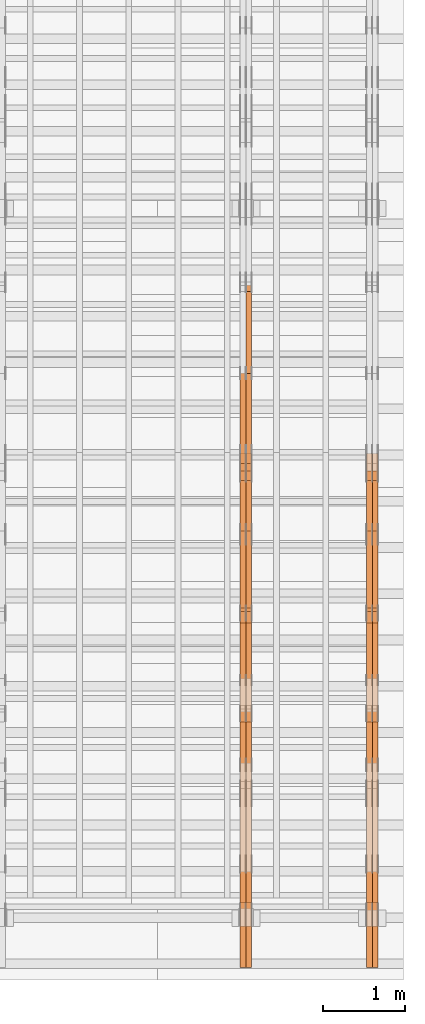
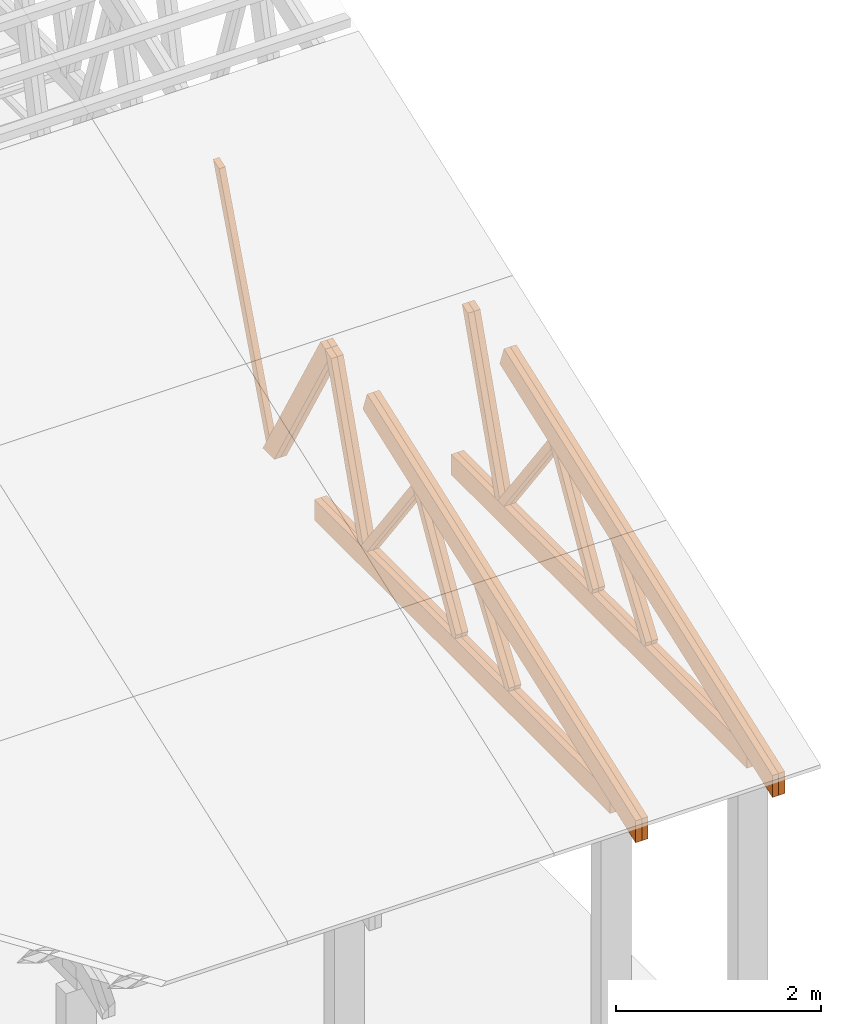
# One storey, part 54 of 189: 27 proxies.
"""IFC2X3 building model written with IfcOpenShell, lengths in millimetres."""

from ifc_helpers import new_model, entity, si_unit, converted_unit, derived_unit, direction, frame, origin, place, context, subcontext, project, spatial, polyline, outline, extrude, source, transform, mapped, material, type_object, type_shapes, element, save


model = new_model("IFC2X3")

# Units and contexts
model_context = context("Model", 3, precision=0.01, world=origin(), true_north=direction((6.12303176911189e-17, 1.0)))
body_context = subcontext(model_context, "Body", "Model", "MODEL_VIEW")
ifc_project = project(units=[si_unit("LENGTHUNIT", "METRE", prefix="MILLI"), si_unit("AREAUNIT", "SQUARE_METRE"), si_unit("VOLUMEUNIT", "CUBIC_METRE"), converted_unit("PLANEANGLEUNIT", "DEGREE", entity("IfcRatioMeasure", 0.0174532925199433), si_unit("PLANEANGLEUNIT", "RADIAN"), dimensions=[0, 0, 0, 0, 0, 0, 0]), si_unit("MASSUNIT", "GRAM", prefix="KILO"), derived_unit("MASSDENSITYUNIT", [(si_unit("MASSUNIT", "GRAM", prefix="KILO"), 1), (si_unit("LENGTHUNIT", "METRE"), -3)]), si_unit("TIMEUNIT", "SECOND"), si_unit("FREQUENCYUNIT", "HERTZ"), si_unit("THERMODYNAMICTEMPERATUREUNIT", "DEGREE_CELSIUS"), derived_unit("THERMALTRANSMITTANCEUNIT", [(si_unit("MASSUNIT", "GRAM", prefix="KILO"), 1), (si_unit("THERMODYNAMICTEMPERATUREUNIT", "KELVIN"), -1), (si_unit("TIMEUNIT", "SECOND"), -3)]), derived_unit("VOLUMETRICFLOWRATEUNIT", [(si_unit("LENGTHUNIT", "METRE"), 3), (si_unit("TIMEUNIT", "SECOND"), -1)]), si_unit("ELECTRICCURRENTUNIT", "AMPERE"), si_unit("ELECTRICVOLTAGEUNIT", "VOLT"), si_unit("POWERUNIT", "WATT"), si_unit("FORCEUNIT", "NEWTON"), si_unit("ILLUMINANCEUNIT", "LUX"), si_unit("LUMINOUSFLUXUNIT", "LUMEN"), si_unit("LUMINOUSINTENSITYUNIT", "CANDELA"), derived_unit("USERDEFINED", [(si_unit("MASSUNIT", "GRAM", prefix="KILO"), -1), (si_unit("LENGTHUNIT", "METRE"), -2), (si_unit("TIMEUNIT", "SECOND"), 3), (si_unit("LUMINOUSFLUXUNIT", "LUMEN"), 1)]), derived_unit("LINEARVELOCITYUNIT", [(si_unit("LENGTHUNIT", "METRE"), 1), (si_unit("TIMEUNIT", "SECOND"), -1)]), si_unit("PRESSUREUNIT", "PASCAL"), derived_unit("USERDEFINED", [(si_unit("LENGTHUNIT", "METRE"), -2), (si_unit("MASSUNIT", "GRAM", prefix="KILO"), 1), (si_unit("TIMEUNIT", "SECOND"), -2)])], contexts=[model_context])

# Site, building, storey
site_placement = place(None, origin())
site = spatial("IfcSite", under=ifc_project, at=site_placement, CompositionType="ELEMENT")
building_placement = place(site_placement, origin())
building = spatial("IfcBuilding", under=site, at=building_placement, CompositionType="ELEMENT")
storey_placement = place(building_placement, origin())
storey = spatial("IfcBuildingStorey", under=building, at=storey_placement, Name="Default", CompositionType="ELEMENT", Elevation=0.0)

# Proxies
ifc_material_1 = material(Name="IfcSurfaceStyle #271792")
building_element_proxy_type_1 = type_object("IfcBuildingElementProxyType", Name="T1-W9 271790", PredefinedType="NOTDEFINED", material=ifc_material_1)
shared_shape_1 = source(origin(), body_context, "Body", "SweptSolid", [
    extrude(outline(polyline([(-1227.3969292634, -47.5000382896404), (793.242467803064, -47.5000382896404), (809.267705296822, 1.0956605530188e-05), (776.329919980315, 47.5000328113376), (-1151.4431638168, 47.5000328113376), (-1227.3969292634, -47.5000382896404)])), frame((809.267705296822, 47.5000328113376, 0.0), z_axis=(0.0, 0.0, 1.0), x_axis=(-1.0, 0.0, 0.0)), (0.0, 0.0, 1.0), 69.9999999999999),
])
type_shapes(building_element_proxy_type_1, [shared_shape_1])
proxy_1_placement = place(building_placement, frame((49840.0, 4809.76380889125, 260.184242613649), z_axis=(-1.0, 0.0, 0.0), x_axis=(0.0, 0.31966811847134, 0.947529574226047)))
element("IfcBuildingElementProxy", 1, at=proxy_1_placement, inside=storey, type_object=building_element_proxy_type_1, material=ifc_material_1, Name="T1-W9", context=body_context, shape_type="MappedRepresentation", body=[
    mapped(shared_shape_1, transform((0.0, 0.0, 0.0), scale=1.0)),
])
ifc_material_2 = material(Name="IfcSurfaceStyle #271726")
building_element_proxy_type_2 = type_object("IfcBuildingElementProxyType", Name="T1-W9 271724", PredefinedType="NOTDEFINED", material=ifc_material_2)
shared_shape_2 = source(origin(), body_context, "Body", "SweptSolid", [
    extrude(outline(polyline([(-1227.3969292634, -47.5000382896404), (793.242467803064, -47.5000382896404), (809.267705296822, 1.0956605530188e-05), (776.329919980315, 47.5000328113376), (-1151.4431638168, 47.5000328113376), (-1227.3969292634, -47.5000382896404)])), frame((809.267705296822, 47.5000328113376, 0.0), z_axis=(0.0, 0.0, 1.0), x_axis=(-1.0, 0.0, 0.0)), (0.0, 0.0, 1.0), 69.9999999999999),
])
type_shapes(building_element_proxy_type_2, [shared_shape_2])
proxy_2_placement = place(building_placement, frame((49770.0, 4809.76380889125, 260.184242613649), z_axis=(-1.0, 0.0, 0.0), x_axis=(0.0, 0.31966811847134, 0.947529574226047)))
element("IfcBuildingElementProxy", 2, at=proxy_2_placement, inside=storey, type_object=building_element_proxy_type_2, material=ifc_material_2, Name="T1-W9", context=body_context, shape_type="MappedRepresentation", body=[
    mapped(shared_shape_2, transform((0.0, 0.0, 0.0), scale=1.0)),
])
ifc_material_3 = material(Name="IfcSurfaceStyle #271528")
building_element_proxy_type_3 = type_object("IfcBuildingElementProxyType", Name="T1-W10 271526", PredefinedType="NOTDEFINED", material=ifc_material_3)
shared_shape_3 = source(origin(), body_context, "Body", "SweptSolid", [
    extrude(outline(polyline([(-922.639472665691, -47.5001890573134), (629.920966338637, -47.5001890573134), (650.067737483374, 0.000694680531158376), (635.89112756682, 47.4998417170478), (-993.240358723139, 47.4998417170478), (-922.639472665691, -47.5001890573134)])), frame((650.068202545693, 47.4999816623145, 0.0), z_axis=(0.0, 0.0, 1.0), x_axis=(-1.0, 0.0, 0.0)), (0.0, 0.0, 1.0), 69.9999999999999),
])
type_shapes(building_element_proxy_type_3, [shared_shape_3])
proxy_3_placement = place(building_placement, frame((49840.0, 3874.56126239818, 1563.95828147518), z_axis=(-1.0, 0.0, 0.0), x_axis=(0.0, 0.596486092002, -0.802623412347398)))
element("IfcBuildingElementProxy", 3, at=proxy_3_placement, inside=storey, type_object=building_element_proxy_type_3, material=ifc_material_3, Name="T1-W10", context=body_context, shape_type="MappedRepresentation", body=[
    mapped(shared_shape_3, transform((0.0, 0.0, 0.0), scale=1.0)),
])
ifc_material_4 = material(Name="IfcSurfaceStyle #271462")
building_element_proxy_type_4 = type_object("IfcBuildingElementProxyType", Name="T1-W10 271460", PredefinedType="NOTDEFINED", material=ifc_material_4)
shared_shape_4 = source(origin(), body_context, "Body", "SweptSolid", [
    extrude(outline(polyline([(-922.639472665691, -47.5001890573134), (629.920966338637, -47.5001890573134), (650.067737483374, 0.000694680531158376), (635.89112756682, 47.4998417170478), (-993.240358723139, 47.4998417170478), (-922.639472665691, -47.5001890573134)])), frame((650.068202545693, 47.4999816623145, 0.0), z_axis=(0.0, 0.0, 1.0), x_axis=(-1.0, 0.0, 0.0)), (0.0, 0.0, 1.0), 69.9999999999999),
])
type_shapes(building_element_proxy_type_4, [shared_shape_4])
proxy_4_placement = place(building_placement, frame((49770.0, 3874.56126239818, 1563.95828147518), z_axis=(-1.0, 0.0, 0.0), x_axis=(0.0, 0.596486092002, -0.802623412347398)))
element("IfcBuildingElementProxy", 4, at=proxy_4_placement, inside=storey, type_object=building_element_proxy_type_4, material=ifc_material_4, Name="T1-W10", context=body_context, shape_type="MappedRepresentation", body=[
    mapped(shared_shape_4, transform((0.0, 0.0, 0.0), scale=1.0)),
])
ifc_material_5 = material(Name="IfcSurfaceStyle #271264")
building_element_proxy_type_5 = type_object("IfcBuildingElementProxyType", Name="T1-W11 271262", PredefinedType="NOTDEFINED", material=ifc_material_5)
shared_shape_5 = source(origin(), body_context, "Body", "SweptSolid", [
    extrude(outline(polyline([(593.358012843793, -552.565239103314), (742.388662259985, -552.565239103314), (-410.498749190676, 401.275038694583), (-462.246133468927, 382.44069706518), (-463.001792444175, 321.414742446865), (593.358012843793, -552.565239103314)])), frame((599.94412413079, 47.5003788877286, 0.0), z_axis=(0.0, 0.0, 1.0), x_axis=(0.770483455324544, 0.637459994879013, 0.0)), (0.0, 0.0, 1.0), 69.9999999999999),
])
type_shapes(building_element_proxy_type_5, [shared_shape_5])
proxy_5_placement = place(building_placement, frame((49840.0, 2983.26655629375, 269.034992751429), z_axis=(-1.0, 0.0, 0.0), x_axis=(0.0, 0.505995901100606, 0.862535882192379)))
element("IfcBuildingElementProxy", 5, at=proxy_5_placement, inside=storey, type_object=building_element_proxy_type_5, material=ifc_material_5, Name="T1-W11", context=body_context, shape_type="MappedRepresentation", body=[
    mapped(shared_shape_5, transform((0.0, 0.0, 0.0), scale=1.0)),
])
ifc_material_6 = material(Name="IfcSurfaceStyle #271198")
building_element_proxy_type_6 = type_object("IfcBuildingElementProxyType", Name="T1-W11 271196", PredefinedType="NOTDEFINED", material=ifc_material_6)
shared_shape_6 = source(origin(), body_context, "Body", "SweptSolid", [
    extrude(outline(polyline([(593.358012843793, -552.565239103314), (742.388662259985, -552.565239103314), (-410.498749190676, 401.275038694583), (-462.246133468927, 382.44069706518), (-463.001792444175, 321.414742446865), (593.358012843793, -552.565239103314)])), frame((599.94412413079, 47.5003788877286, 0.0), z_axis=(0.0, 0.0, 1.0), x_axis=(0.770483455324544, 0.637459994879013, 0.0)), (0.0, 0.0, 1.0), 69.9999999999999),
])
type_shapes(building_element_proxy_type_6, [shared_shape_6])
proxy_6_placement = place(building_placement, frame((49770.0, 2983.26655629375, 269.034992751429), z_axis=(-1.0, 0.0, 0.0), x_axis=(0.0, 0.505995901100606, 0.862535882192379)))
element("IfcBuildingElementProxy", 6, at=proxy_6_placement, inside=storey, type_object=building_element_proxy_type_6, material=ifc_material_6, Name="T1-W11", context=body_context, shape_type="MappedRepresentation", body=[
    mapped(shared_shape_6, transform((0.0, 0.0, 0.0), scale=1.0)),
])
ifc_material_7 = material(Name="IfcSurfaceStyle #270736")
building_element_proxy_type_7 = type_object("IfcBuildingElementProxyType", Name="T1-W13 270734", PredefinedType="NOTDEFINED", material=ifc_material_7)
shared_shape_7 = source(origin(), body_context, "Body", "SweptSolid", [
    extrude(outline(polyline([(404.740440720218, -341.48092914206), (570.336320797765, -341.48092914206), (-287.911826743206, 259.650691447848), (-342.395697357435, 239.820346030744), (-344.769237417342, 183.490820805529), (404.740440720218, -341.48092914206)])), frame((418.029573061951, 47.5005675782689, 0.0), z_axis=(0.0, 0.0, 1.0), x_axis=(0.819070847746389, 0.573692379565924, 0.0)), (0.0, 0.0, 1.0), 69.9999999999999),
])
type_shapes(building_element_proxy_type_7, [shared_shape_7])
proxy_7_placement = place(building_placement, frame((49840.0, 1951.16403402681, 272.239720286334), z_axis=(-1.0, 0.0, 0.0), x_axis=(0.0, 0.573462629043499, 0.819231721242848)))
element("IfcBuildingElementProxy", 7, at=proxy_7_placement, inside=storey, type_object=building_element_proxy_type_7, material=ifc_material_7, Name="T1-W13", context=body_context, shape_type="MappedRepresentation", body=[
    mapped(shared_shape_7, transform((0.0, 0.0, 0.0), scale=1.0)),
])
ifc_material_8 = material(Name="IfcSurfaceStyle #270670")
building_element_proxy_type_8 = type_object("IfcBuildingElementProxyType", Name="T1-W13 270668", PredefinedType="NOTDEFINED", material=ifc_material_8)
shared_shape_8 = source(origin(), body_context, "Body", "SweptSolid", [
    extrude(outline(polyline([(404.740440720218, -341.48092914206), (570.336320797765, -341.48092914206), (-287.911826743206, 259.650691447848), (-342.395697357435, 239.820346030744), (-344.769237417342, 183.490820805529), (404.740440720218, -341.48092914206)])), frame((418.029573061951, 47.5005675782689, 0.0), z_axis=(0.0, 0.0, 1.0), x_axis=(0.819070847746389, 0.573692379565924, 0.0)), (0.0, 0.0, 1.0), 69.9999999999999),
])
type_shapes(building_element_proxy_type_8, [shared_shape_8])
proxy_8_placement = place(building_placement, frame((49770.0, 1951.16403402681, 272.239720286334), z_axis=(-1.0, 0.0, 0.0), x_axis=(0.0, 0.573462629043499, 0.819231721242848)))
element("IfcBuildingElementProxy", 8, at=proxy_8_placement, inside=storey, type_object=building_element_proxy_type_8, material=ifc_material_8, Name="T1-W13", context=body_context, shape_type="MappedRepresentation", body=[
    mapped(shared_shape_8, transform((0.0, 0.0, 0.0), scale=1.0)),
])
ifc_material_9 = material(Name="IfcSurfaceStyle #269392")
building_element_proxy_type_9 = type_object("IfcBuildingElementProxyType", Name="T1-B2 269390", PredefinedType="NOTDEFINED", material=ifc_material_9)
shared_shape_9 = source(origin(), body_context, "Body", "SweptSolid", [
    extrude(outline(polyline([(-3399.385546875, -125.855288696291), (2363.08125, -125.855288696291), (2363.08125, 13.4211547851572), (2072.60859375, 119.144711303712), (-3399.385546875, 119.144711303712), (-3399.385546875, -125.855288696291)])), frame((2363.08125, 119.144711303712, 0.0), z_axis=(0.0, 0.0, 1.0), x_axis=(-1.0, 0.0, 0.0)), (0.0, 0.0, 1.0), 69.9999999999997),
])
type_shapes(building_element_proxy_type_9, [shared_shape_9])
proxy_9_placement = place(building_placement, frame((49840.0, 0.0, 245.0), z_axis=(-1.0, 0.0, 0.0), x_axis=(0.0, 1.0, 0.0)))
element("IfcBuildingElementProxy", 9, at=proxy_9_placement, inside=storey, type_object=building_element_proxy_type_9, material=ifc_material_9, Name="T1-B2", context=body_context, shape_type="MappedRepresentation", body=[
    mapped(shared_shape_9, transform((0.0, 0.0, 0.0), scale=1.0)),
])
ifc_material_10 = material(Name="IfcSurfaceStyle #269326")
building_element_proxy_type_10 = type_object("IfcBuildingElementProxyType", Name="T1-B2 269324", PredefinedType="NOTDEFINED", material=ifc_material_10)
shared_shape_10 = source(origin(), body_context, "Body", "SweptSolid", [
    extrude(outline(polyline([(-3399.385546875, -125.855288696291), (2363.08125, -125.855288696291), (2363.08125, 13.4211547851572), (2072.60859375, 119.144711303712), (-3399.385546875, 119.144711303712), (-3399.385546875, -125.855288696291)])), frame((2363.08125, 119.144711303712, 0.0), z_axis=(0.0, 0.0, 1.0), x_axis=(-1.0, 0.0, 0.0)), (0.0, 0.0, 1.0), 69.9999999999997),
])
type_shapes(building_element_proxy_type_10, [shared_shape_10])
proxy_10_placement = place(building_placement, frame((49770.0, 0.0, 245.0), z_axis=(-1.0, 0.0, 0.0), x_axis=(0.0, 1.0, 0.0)))
element("IfcBuildingElementProxy", 10, at=proxy_10_placement, inside=storey, type_object=building_element_proxy_type_10, material=ifc_material_10, Name="T1-B2", context=body_context, shape_type="MappedRepresentation", body=[
    mapped(shared_shape_10, transform((0.0, 0.0, 0.0), scale=1.0)),
])
ifc_material_11 = material(Name="IfcSurfaceStyle #269260")
building_element_proxy_type_11 = type_object("IfcBuildingElementProxyType", Name="T1-T2 269258", PredefinedType="NOTDEFINED", material=ifc_material_11)
shared_shape_11 = source(origin(), body_context, "Body", "SweptSolid", [
    extrude(outline(polyline([(-2763.12044548193, -122.499971764318), (2807.70681121203, -122.499971764318), (2807.70678531127, 122.499971764318), (-2852.29315104137, 122.499971764318), (-2763.12044548193, -122.499971764318)])), frame((2807.70684902043, 122.500023191939, 0.0), z_axis=(0.0, 0.0, 1.0), x_axis=(-1.0, 0.0, 0.0)), (0.0, 0.0, 1.0), 69.9999999999997),
])
type_shapes(building_element_proxy_type_11, [shared_shape_11])
proxy_11_placement = place(building_placement, frame((49840.0, 4818.66023370631, 1893.1253396746), z_axis=(-1.0, 0.0, 0.0), x_axis=(0.0, -0.939692620785908, -0.342020143325669)))
element("IfcBuildingElementProxy", 11, at=proxy_11_placement, inside=storey, type_object=building_element_proxy_type_11, material=ifc_material_11, Name="T1-T2", context=body_context, shape_type="MappedRepresentation", body=[
    mapped(shared_shape_11, transform((0.0, 0.0, 0.0), scale=1.0)),
])
ifc_material_12 = material(Name="IfcSurfaceStyle #269203")
building_element_proxy_type_12 = type_object("IfcBuildingElementProxyType", Name="T1-T2 269201", PredefinedType="NOTDEFINED", material=ifc_material_12)
shared_shape_12 = source(origin(), body_context, "Body", "SweptSolid", [
    extrude(outline(polyline([(-2763.12044548193, -122.499971764318), (2807.70681121203, -122.499971764318), (2807.70678531127, 122.499971764318), (-2852.29315104137, 122.499971764318), (-2763.12044548193, -122.499971764318)])), frame((2807.70684902043, 122.500023191939, 0.0), z_axis=(0.0, 0.0, 1.0), x_axis=(-1.0, 0.0, 0.0)), (0.0, 0.0, 1.0), 69.9999999999997),
])
type_shapes(building_element_proxy_type_12, [shared_shape_12])
proxy_12_placement = place(building_placement, frame((49770.0, 4818.66023370631, 1893.1253396746), z_axis=(-1.0, 0.0, 0.0), x_axis=(0.0, -0.939692620785908, -0.342020143325669)))
element("IfcBuildingElementProxy", 12, at=proxy_12_placement, inside=storey, type_object=building_element_proxy_type_12, material=ifc_material_12, Name="T1-T2", context=body_context, shape_type="MappedRepresentation", body=[
    mapped(shared_shape_12, transform((0.0, 0.0, 0.0), scale=1.0)),
])
ifc_material_13 = material(Name="IfcSurfaceStyle #256530")
building_element_proxy_type_13 = type_object("IfcBuildingElementProxyType", Name="T1-W8 256528", PredefinedType="NOTDEFINED", material=ifc_material_13)
shared_shape_13 = source(origin(), body_context, "Body", "SweptSolid", [
    extrude(outline(polyline([(-1781.70529904483, -47.500320228718), (1161.65050357787, -47.5003202287179), (1179.56135870849, 0.000731866266039397), (1140.6022069428, 47.4998218997103), (-1700.10877018433, 47.5000866914596), (-1781.70529904483, -47.500320228718)])), frame((1179.56135870869, 47.5007236522113, 0.0), z_axis=(0.0, 0.0, 1.0), x_axis=(-1.0, 3.74658825645258e-07, 0.0)), (0.0, 0.0, 1.0), 69.9999999999998),
])
type_shapes(building_element_proxy_type_13, [shared_shape_13])
proxy_13_placement = place(building_placement, frame((48300.0, 6723.5697965901, 261.758864533503), z_axis=(-1.0, 0.0, 0.0), x_axis=(0.0, 0.352814979177603, 0.93569310698963)))
element("IfcBuildingElementProxy", 13, at=proxy_13_placement, inside=storey, type_object=building_element_proxy_type_13, material=ifc_material_13, Name="T1-W8", context=body_context, shape_type="MappedRepresentation", body=[
    mapped(shared_shape_13, transform((0.0, 0.0, 0.0), scale=1.0)),
])
ifc_material_14 = material(Name="IfcSurfaceStyle #256266")
building_element_proxy_type_14 = type_object("IfcBuildingElementProxyType", Name="T1-W2 256264", PredefinedType="NOTDEFINED", material=ifc_material_14)
shared_shape_14 = source(origin(), body_context, "Body", "SweptSolid", [
    extrude(outline(polyline([(-765.033104991319, -1130.91940266317), (-539.905732758898, -1130.91940266317), (493.678280567457, 660.584515081422), (452.144945212405, 783.697385511457), (359.115611970356, 817.556904733455), (-765.033104991319, -1130.91940266317)])), frame((904.774360566371, 97.5002668805543, 0.0), z_axis=(0.0, 0.0, 1.0), x_axis=(-0.499731715721184, 0.866180242387438, 0.0)), (0.0, 0.0, 1.0), 69.9999999999998),
])
type_shapes(building_element_proxy_type_14, [shared_shape_14])
proxy_14_placement = place(building_placement, frame((48300.0, 5635.28919163287, 2208.3400784451), z_axis=(-1.0, 0.0, 0.0), x_axis=(0.0, 0.5, -0.866025403784439)))
element("IfcBuildingElementProxy", 14, at=proxy_14_placement, inside=storey, type_object=building_element_proxy_type_14, material=ifc_material_14, Name="T1-W2", context=body_context, shape_type="MappedRepresentation", body=[
    mapped(shared_shape_14, transform((0.0, 0.0, 0.0), scale=1.0)),
])
ifc_material_15 = material(Name="IfcSurfaceStyle #256200")
building_element_proxy_type_15 = type_object("IfcBuildingElementProxyType", Name="T1-W2 256198", PredefinedType="NOTDEFINED", material=ifc_material_15)
shared_shape_15 = source(origin(), body_context, "Body", "SweptSolid", [
    extrude(outline(polyline([(-765.033104991319, -1130.91940266317), (-539.905732758898, -1130.91940266317), (493.678280567457, 660.584515081422), (452.144945212405, 783.697385511457), (359.115611970356, 817.556904733455), (-765.033104991319, -1130.91940266317)])), frame((904.774360566371, 97.5002668805543, 0.0), z_axis=(0.0, 0.0, 1.0), x_axis=(-0.499731715721184, 0.866180242387438, 0.0)), (0.0, 0.0, 1.0), 69.9999999999998),
])
type_shapes(building_element_proxy_type_15, [shared_shape_15])
proxy_15_placement = place(building_placement, frame((48230.0, 5635.28919163287, 2208.3400784451), z_axis=(-1.0, 0.0, 0.0), x_axis=(0.0, 0.5, -0.866025403784439)))
element("IfcBuildingElementProxy", 15, at=proxy_15_placement, inside=storey, type_object=building_element_proxy_type_15, material=ifc_material_15, Name="T1-W2", context=body_context, shape_type="MappedRepresentation", body=[
    mapped(shared_shape_15, transform((0.0, 0.0, 0.0), scale=1.0)),
])
ifc_material_16 = material(Name="IfcSurfaceStyle #256002")
building_element_proxy_type_16 = type_object("IfcBuildingElementProxyType", Name="T1-W9 256000", PredefinedType="NOTDEFINED", material=ifc_material_16)
shared_shape_16 = source(origin(), body_context, "Body", "SweptSolid", [
    extrude(outline(polyline([(-1227.3969292634, -47.5000382896404), (793.242467803064, -47.5000382896404), (809.267705296822, 1.0956605530188e-05), (776.329919980315, 47.5000328113376), (-1151.4431638168, 47.5000328113376), (-1227.3969292634, -47.5000382896404)])), frame((809.267705296822, 47.5000328113376, 0.0), z_axis=(0.0, 0.0, 1.0), x_axis=(-1.0, 0.0, 0.0)), (0.0, 0.0, 1.0), 69.9999999999999),
])
type_shapes(building_element_proxy_type_16, [shared_shape_16])
proxy_16_placement = place(building_placement, frame((48300.0, 4809.76380889125, 260.184242613649), z_axis=(-1.0, 0.0, 0.0), x_axis=(0.0, 0.31966811847134, 0.947529574226047)))
element("IfcBuildingElementProxy", 16, at=proxy_16_placement, inside=storey, type_object=building_element_proxy_type_16, material=ifc_material_16, Name="T1-W9", context=body_context, shape_type="MappedRepresentation", body=[
    mapped(shared_shape_16, transform((0.0, 0.0, 0.0), scale=1.0)),
])
ifc_material_17 = material(Name="IfcSurfaceStyle #255936")
building_element_proxy_type_17 = type_object("IfcBuildingElementProxyType", Name="T1-W9 255934", PredefinedType="NOTDEFINED", material=ifc_material_17)
shared_shape_17 = source(origin(), body_context, "Body", "SweptSolid", [
    extrude(outline(polyline([(-1227.3969292634, -47.5000382896404), (793.242467803064, -47.5000382896404), (809.267705296822, 1.0956605530188e-05), (776.329919980315, 47.5000328113376), (-1151.4431638168, 47.5000328113376), (-1227.3969292634, -47.5000382896404)])), frame((809.267705296822, 47.5000328113376, 0.0), z_axis=(0.0, 0.0, 1.0), x_axis=(-1.0, 0.0, 0.0)), (0.0, 0.0, 1.0), 69.9999999999999),
])
type_shapes(building_element_proxy_type_17, [shared_shape_17])
proxy_17_placement = place(building_placement, frame((48230.0, 4809.76380889125, 260.184242613649), z_axis=(-1.0, 0.0, 0.0), x_axis=(0.0, 0.31966811847134, 0.947529574226047)))
element("IfcBuildingElementProxy", 17, at=proxy_17_placement, inside=storey, type_object=building_element_proxy_type_17, material=ifc_material_17, Name="T1-W9", context=body_context, shape_type="MappedRepresentation", body=[
    mapped(shared_shape_17, transform((0.0, 0.0, 0.0), scale=1.0)),
])
ifc_material_18 = material(Name="IfcSurfaceStyle #255738")
building_element_proxy_type_18 = type_object("IfcBuildingElementProxyType", Name="T1-W10 255736", PredefinedType="NOTDEFINED", material=ifc_material_18)
shared_shape_18 = source(origin(), body_context, "Body", "SweptSolid", [
    extrude(outline(polyline([(-922.639472665691, -47.5001890573134), (629.920966338637, -47.5001890573134), (650.067737483374, 0.000694680531158376), (635.89112756682, 47.4998417170478), (-993.240358723139, 47.4998417170478), (-922.639472665691, -47.5001890573134)])), frame((650.068202545693, 47.4999816623145, 0.0), z_axis=(0.0, 0.0, 1.0), x_axis=(-1.0, 0.0, 0.0)), (0.0, 0.0, 1.0), 69.9999999999999),
])
type_shapes(building_element_proxy_type_18, [shared_shape_18])
proxy_18_placement = place(building_placement, frame((48300.0, 3874.56126239818, 1563.95828147518), z_axis=(-1.0, 0.0, 0.0), x_axis=(0.0, 0.596486092002, -0.802623412347398)))
element("IfcBuildingElementProxy", 18, at=proxy_18_placement, inside=storey, type_object=building_element_proxy_type_18, material=ifc_material_18, Name="T1-W10", context=body_context, shape_type="MappedRepresentation", body=[
    mapped(shared_shape_18, transform((0.0, 0.0, 0.0), scale=1.0)),
])
ifc_material_19 = material(Name="IfcSurfaceStyle #255672")
building_element_proxy_type_19 = type_object("IfcBuildingElementProxyType", Name="T1-W10 255670", PredefinedType="NOTDEFINED", material=ifc_material_19)
shared_shape_19 = source(origin(), body_context, "Body", "SweptSolid", [
    extrude(outline(polyline([(-922.639472665691, -47.5001890573134), (629.920966338637, -47.5001890573134), (650.067737483374, 0.000694680531158376), (635.89112756682, 47.4998417170478), (-993.240358723139, 47.4998417170478), (-922.639472665691, -47.5001890573134)])), frame((650.068202545693, 47.4999816623145, 0.0), z_axis=(0.0, 0.0, 1.0), x_axis=(-1.0, 0.0, 0.0)), (0.0, 0.0, 1.0), 69.9999999999999),
])
type_shapes(building_element_proxy_type_19, [shared_shape_19])
proxy_19_placement = place(building_placement, frame((48230.0, 3874.56126239818, 1563.95828147518), z_axis=(-1.0, 0.0, 0.0), x_axis=(0.0, 0.596486092002, -0.802623412347398)))
element("IfcBuildingElementProxy", 19, at=proxy_19_placement, inside=storey, type_object=building_element_proxy_type_19, material=ifc_material_19, Name="T1-W10", context=body_context, shape_type="MappedRepresentation", body=[
    mapped(shared_shape_19, transform((0.0, 0.0, 0.0), scale=1.0)),
])
ifc_material_20 = material(Name="IfcSurfaceStyle #255474")
building_element_proxy_type_20 = type_object("IfcBuildingElementProxyType", Name="T1-W11 255472", PredefinedType="NOTDEFINED", material=ifc_material_20)
shared_shape_20 = source(origin(), body_context, "Body", "SweptSolid", [
    extrude(outline(polyline([(593.358012843793, -552.565239103314), (742.388662259985, -552.565239103314), (-410.498749190676, 401.275038694583), (-462.246133468927, 382.44069706518), (-463.001792444175, 321.414742446865), (593.358012843793, -552.565239103314)])), frame((599.94412413079, 47.5003788877286, 0.0), z_axis=(0.0, 0.0, 1.0), x_axis=(0.770483455324544, 0.637459994879013, 0.0)), (0.0, 0.0, 1.0), 69.9999999999999),
])
type_shapes(building_element_proxy_type_20, [shared_shape_20])
proxy_20_placement = place(building_placement, frame((48300.0, 2983.26655629375, 269.034992751429), z_axis=(-1.0, 0.0, 0.0), x_axis=(0.0, 0.505995901100606, 0.862535882192379)))
element("IfcBuildingElementProxy", 20, at=proxy_20_placement, inside=storey, type_object=building_element_proxy_type_20, material=ifc_material_20, Name="T1-W11", context=body_context, shape_type="MappedRepresentation", body=[
    mapped(shared_shape_20, transform((0.0, 0.0, 0.0), scale=1.0)),
])
ifc_material_21 = material(Name="IfcSurfaceStyle #255408")
building_element_proxy_type_21 = type_object("IfcBuildingElementProxyType", Name="T1-W11 255406", PredefinedType="NOTDEFINED", material=ifc_material_21)
shared_shape_21 = source(origin(), body_context, "Body", "SweptSolid", [
    extrude(outline(polyline([(593.358012843793, -552.565239103314), (742.388662259985, -552.565239103314), (-410.498749190676, 401.275038694583), (-462.246133468927, 382.44069706518), (-463.001792444175, 321.414742446865), (593.358012843793, -552.565239103314)])), frame((599.94412413079, 47.5003788877286, 0.0), z_axis=(0.0, 0.0, 1.0), x_axis=(0.770483455324544, 0.637459994879013, 0.0)), (0.0, 0.0, 1.0), 69.9999999999999),
])
type_shapes(building_element_proxy_type_21, [shared_shape_21])
proxy_21_placement = place(building_placement, frame((48230.0, 2983.26655629375, 269.034992751429), z_axis=(-1.0, 0.0, 0.0), x_axis=(0.0, 0.505995901100606, 0.862535882192379)))
element("IfcBuildingElementProxy", 21, at=proxy_21_placement, inside=storey, type_object=building_element_proxy_type_21, material=ifc_material_21, Name="T1-W11", context=body_context, shape_type="MappedRepresentation", body=[
    mapped(shared_shape_21, transform((0.0, 0.0, 0.0), scale=1.0)),
])
ifc_material_22 = material(Name="IfcSurfaceStyle #254946")
building_element_proxy_type_22 = type_object("IfcBuildingElementProxyType", Name="T1-W13 254944", PredefinedType="NOTDEFINED", material=ifc_material_22)
shared_shape_22 = source(origin(), body_context, "Body", "SweptSolid", [
    extrude(outline(polyline([(404.740440720218, -341.48092914206), (570.336320797765, -341.48092914206), (-287.911826743206, 259.650691447848), (-342.395697357435, 239.820346030744), (-344.769237417342, 183.490820805529), (404.740440720218, -341.48092914206)])), frame((418.029573061951, 47.5005675782689, 0.0), z_axis=(0.0, 0.0, 1.0), x_axis=(0.819070847746389, 0.573692379565924, 0.0)), (0.0, 0.0, 1.0), 69.9999999999999),
])
type_shapes(building_element_proxy_type_22, [shared_shape_22])
proxy_22_placement = place(building_placement, frame((48300.0, 1951.16403402681, 272.239720286334), z_axis=(-1.0, 0.0, 0.0), x_axis=(0.0, 0.573462629043499, 0.819231721242848)))
element("IfcBuildingElementProxy", 22, at=proxy_22_placement, inside=storey, type_object=building_element_proxy_type_22, material=ifc_material_22, Name="T1-W13", context=body_context, shape_type="MappedRepresentation", body=[
    mapped(shared_shape_22, transform((0.0, 0.0, 0.0), scale=1.0)),
])
ifc_material_23 = material(Name="IfcSurfaceStyle #254880")
building_element_proxy_type_23 = type_object("IfcBuildingElementProxyType", Name="T1-W13 254878", PredefinedType="NOTDEFINED", material=ifc_material_23)
shared_shape_23 = source(origin(), body_context, "Body", "SweptSolid", [
    extrude(outline(polyline([(404.740440720218, -341.48092914206), (570.336320797765, -341.48092914206), (-287.911826743206, 259.650691447848), (-342.395697357435, 239.820346030744), (-344.769237417342, 183.490820805529), (404.740440720218, -341.48092914206)])), frame((418.029573061951, 47.5005675782689, 0.0), z_axis=(0.0, 0.0, 1.0), x_axis=(0.819070847746389, 0.573692379565924, 0.0)), (0.0, 0.0, 1.0), 69.9999999999999),
])
type_shapes(building_element_proxy_type_23, [shared_shape_23])
proxy_23_placement = place(building_placement, frame((48230.0, 1951.16403402681, 272.239720286334), z_axis=(-1.0, 0.0, 0.0), x_axis=(0.0, 0.573462629043499, 0.819231721242848)))
element("IfcBuildingElementProxy", 23, at=proxy_23_placement, inside=storey, type_object=building_element_proxy_type_23, material=ifc_material_23, Name="T1-W13", context=body_context, shape_type="MappedRepresentation", body=[
    mapped(shared_shape_23, transform((0.0, 0.0, 0.0), scale=1.0)),
])
ifc_material_24 = material(Name="IfcSurfaceStyle #253602")
building_element_proxy_type_24 = type_object("IfcBuildingElementProxyType", Name="T1-B2 253600", PredefinedType="NOTDEFINED", material=ifc_material_24)
shared_shape_24 = source(origin(), body_context, "Body", "SweptSolid", [
    extrude(outline(polyline([(-3399.385546875, -125.855288696291), (2363.08125, -125.855288696291), (2363.08125, 13.4211547851572), (2072.60859375, 119.144711303712), (-3399.385546875, 119.144711303712), (-3399.385546875, -125.855288696291)])), frame((2363.08125, 119.144711303712, 0.0), z_axis=(0.0, 0.0, 1.0), x_axis=(-1.0, 0.0, 0.0)), (0.0, 0.0, 1.0), 69.9999999999997),
])
type_shapes(building_element_proxy_type_24, [shared_shape_24])
proxy_24_placement = place(building_placement, frame((48300.0, 0.0, 245.0), z_axis=(-1.0, 0.0, 0.0), x_axis=(0.0, 1.0, 0.0)))
element("IfcBuildingElementProxy", 24, at=proxy_24_placement, inside=storey, type_object=building_element_proxy_type_24, material=ifc_material_24, Name="T1-B2", context=body_context, shape_type="MappedRepresentation", body=[
    mapped(shared_shape_24, transform((0.0, 0.0, 0.0), scale=1.0)),
])
ifc_material_25 = material(Name="IfcSurfaceStyle #253536")
building_element_proxy_type_25 = type_object("IfcBuildingElementProxyType", Name="T1-B2 253534", PredefinedType="NOTDEFINED", material=ifc_material_25)
shared_shape_25 = source(origin(), body_context, "Body", "SweptSolid", [
    extrude(outline(polyline([(-3399.385546875, -125.855288696291), (2363.08125, -125.855288696291), (2363.08125, 13.4211547851572), (2072.60859375, 119.144711303712), (-3399.385546875, 119.144711303712), (-3399.385546875, -125.855288696291)])), frame((2363.08125, 119.144711303712, 0.0), z_axis=(0.0, 0.0, 1.0), x_axis=(-1.0, 0.0, 0.0)), (0.0, 0.0, 1.0), 69.9999999999997),
])
type_shapes(building_element_proxy_type_25, [shared_shape_25])
proxy_25_placement = place(building_placement, frame((48230.0, 0.0, 245.0), z_axis=(-1.0, 0.0, 0.0), x_axis=(0.0, 1.0, 0.0)))
element("IfcBuildingElementProxy", 25, at=proxy_25_placement, inside=storey, type_object=building_element_proxy_type_25, material=ifc_material_25, Name="T1-B2", context=body_context, shape_type="MappedRepresentation", body=[
    mapped(shared_shape_25, transform((0.0, 0.0, 0.0), scale=1.0)),
])
ifc_material_26 = material(Name="IfcSurfaceStyle #253470")
building_element_proxy_type_26 = type_object("IfcBuildingElementProxyType", Name="T1-T2 253468", PredefinedType="NOTDEFINED", material=ifc_material_26)
shared_shape_26 = source(origin(), body_context, "Body", "SweptSolid", [
    extrude(outline(polyline([(-2763.12044548193, -122.499971764318), (2807.70681121203, -122.499971764318), (2807.70678531127, 122.499971764318), (-2852.29315104137, 122.499971764318), (-2763.12044548193, -122.499971764318)])), frame((2807.70684902043, 122.500023191939, 0.0), z_axis=(0.0, 0.0, 1.0), x_axis=(-1.0, 0.0, 0.0)), (0.0, 0.0, 1.0), 69.9999999999997),
])
type_shapes(building_element_proxy_type_26, [shared_shape_26])
proxy_26_placement = place(building_placement, frame((48300.0, 4818.66023370631, 1893.1253396746), z_axis=(-1.0, 0.0, 0.0), x_axis=(0.0, -0.939692620785908, -0.342020143325669)))
element("IfcBuildingElementProxy", 26, at=proxy_26_placement, inside=storey, type_object=building_element_proxy_type_26, material=ifc_material_26, Name="T1-T2", context=body_context, shape_type="MappedRepresentation", body=[
    mapped(shared_shape_26, transform((0.0, 0.0, 0.0), scale=1.0)),
])
ifc_material_27 = material(Name="IfcSurfaceStyle #253413")
building_element_proxy_type_27 = type_object("IfcBuildingElementProxyType", Name="T1-T2 253411", PredefinedType="NOTDEFINED", material=ifc_material_27)
shared_shape_27 = source(origin(), body_context, "Body", "SweptSolid", [
    extrude(outline(polyline([(-2763.12044548193, -122.499971764318), (2807.70681121203, -122.499971764318), (2807.70678531127, 122.499971764318), (-2852.29315104137, 122.499971764318), (-2763.12044548193, -122.499971764318)])), frame((2807.70684902043, 122.500023191939, 0.0), z_axis=(0.0, 0.0, 1.0), x_axis=(-1.0, 0.0, 0.0)), (0.0, 0.0, 1.0), 69.9999999999997),
])
type_shapes(building_element_proxy_type_27, [shared_shape_27])
proxy_27_placement = place(building_placement, frame((48230.0, 4818.66023370631, 1893.1253396746), z_axis=(-1.0, 0.0, 0.0), x_axis=(0.0, -0.939692620785908, -0.342020143325669)))
element("IfcBuildingElementProxy", 27, at=proxy_27_placement, inside=storey, type_object=building_element_proxy_type_27, material=ifc_material_27, Name="T1-T2", context=body_context, shape_type="MappedRepresentation", body=[
    mapped(shared_shape_27, transform((0.0, 0.0, 0.0), scale=1.0)),
])

save(model, "model.ifc")
